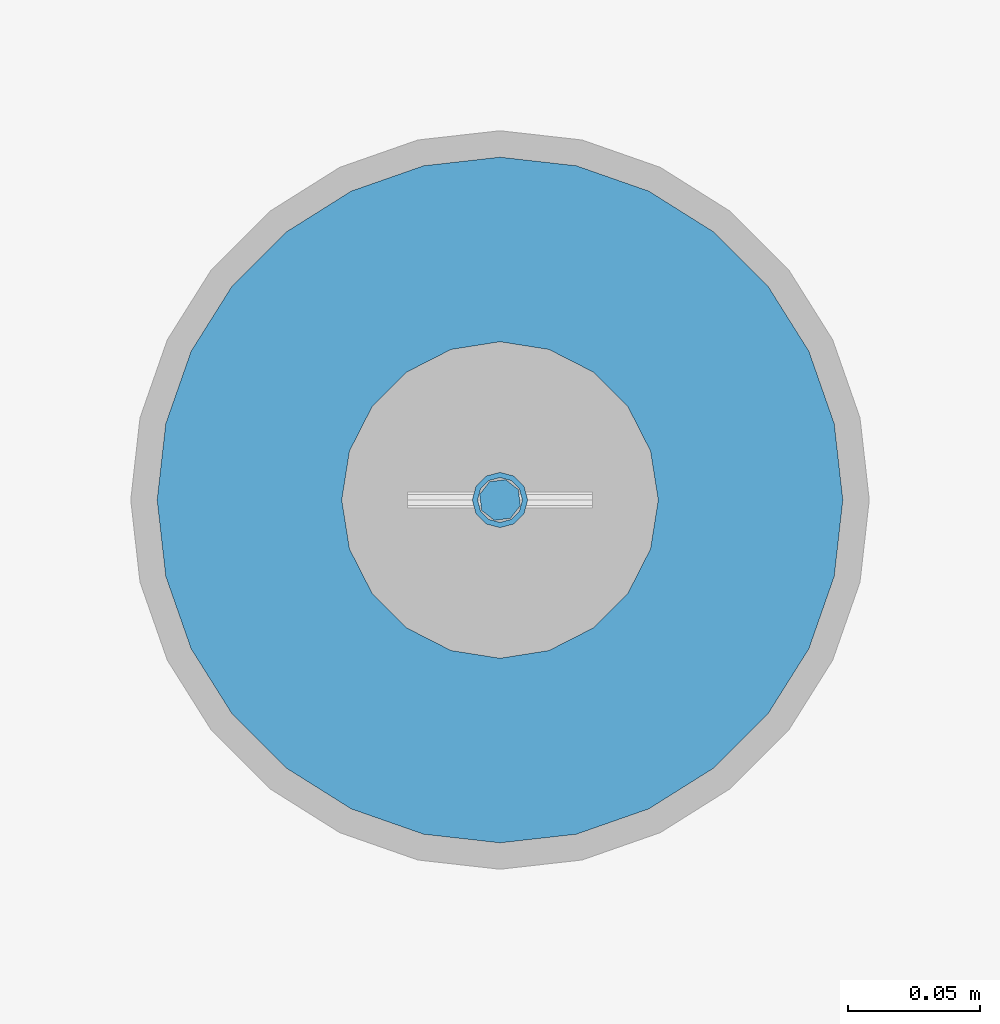
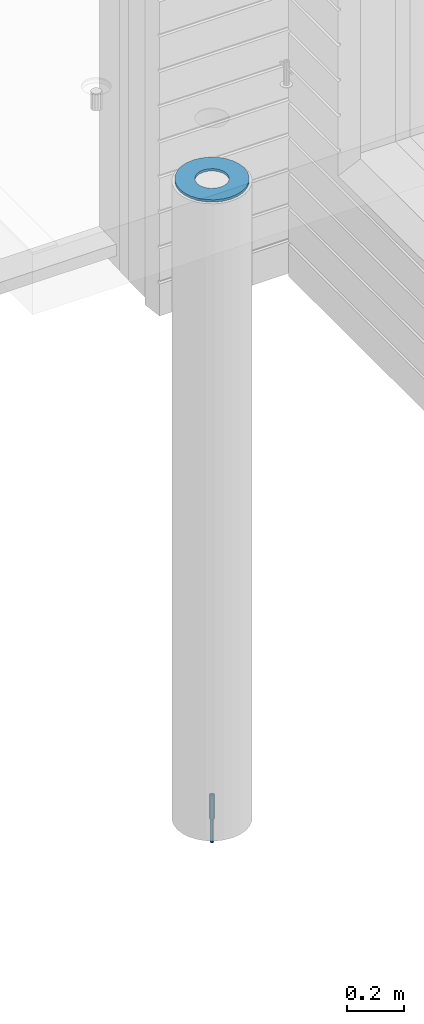
# One storey, part 7 of 309: 3 columns, 3 elements without a shape of their own.
"""IFC2X3 building model written with IfcOpenShell, lengths in millimetres."""

from ifc_helpers import new_model, si_unit, frame, origin_with_axes, place, context, subcontext, project, spatial, faceted_brep, material, type_object, element, aggregate, save


model = new_model("IFC2X3")

# Units and contexts
model_context = context("Model", 3, precision=1e-05, world=origin_with_axes())
body_context = subcontext(model_context, "Body", "Model", "MODEL_VIEW")
ifc_project = project(units=[si_unit("LENGTHUNIT", "METRE", prefix="MILLI"), si_unit("AREAUNIT", "SQUARE_METRE"), si_unit("VOLUMEUNIT", "CUBIC_METRE"), si_unit("MASSUNIT", "GRAM", prefix="KILO"), si_unit("TIMEUNIT", "SECOND"), si_unit("PLANEANGLEUNIT", "RADIAN"), si_unit("SOLIDANGLEUNIT", "STERADIAN"), si_unit("THERMODYNAMICTEMPERATUREUNIT", "DEGREE_CELSIUS"), si_unit("LUMINOUSINTENSITYUNIT", "LUMEN")], contexts=[model_context])

# Site, building, storey
site_placement = place(None, origin_with_axes())
site = spatial("IfcSite", under=ifc_project, at=site_placement, CompositionType="ELEMENT")
building_placement = place(site_placement, origin_with_axes())
building = spatial("IfcBuilding", under=site, at=building_placement, CompositionType="ELEMENT")
storey_placement = place(building_placement, origin_with_axes())
storey = spatial("IfcBuildingStorey", under=building, at=storey_placement, Name="7", CompositionType="ELEMENT", Elevation=0.0)

# Assemblies, columns
assembly_1_placement = place(storey_placement, origin_with_axes())
assembly_1 = element("IfcElementAssembly", 1, at=assembly_1_placement, inside=storey, AssemblyPlace="NOTDEFINED", PredefinedType="REINFORCEMENT_UNIT")
assembly_2_placement = place(assembly_1_placement, origin_with_axes())
assembly_2 = element("IfcElementAssembly", 2, at=assembly_2_placement, Name="Steel Assembly", AssemblyPlace="NOTDEFINED", PredefinedType="RIGID_FRAME")
ifc_material_1 = material(Name="STEEL/S235JR")
column_type_1 = type_object("IfcColumnType", Name="D16", PredefinedType="NOTDEFINED")
column_1_placement = place(assembly_2_placement, frame((7850.00048014349, 7949.98420120467, 99625.0), z_axis=(-0.261346946111888, -0.96524492941325, 0.0), x_axis=(0.0, 0.0, 1.0)))
column_1 = element("IfcColumn", 3, at=column_1_placement, type_object=column_type_1, material=ifc_material_1, Name="M16", ObjectType="D16", context=body_context, shape_type="Brep", body=[
    faceted_brep([(0.0, -8.0, 0.0), (0.0, -5.65685424949334, -5.65685424949334), (150.0, -5.65685424949697, -5.65685424949334), (150.0, -8.00000000000364, 0.0), (0.0, 0.0, -8.0), (150.0, -7.27595761418343e-12, -7.99999999999636), (0.0, 5.65685424949334, -5.65685424949334), (150.0, 5.6568542494897, -5.65685424949334), (0.0, 8.0, 0.0), (150.0, 8.0, -3.63797880709171e-12), (0.0, 5.65685424949334, 5.65685424949334), (150.0, 5.65685424949334, 5.65685424949697), (0.0, 0.0, 8.0), (150.0, -3.63797880709171e-12, 8.0), (0.0, -5.65685424949334, 5.65685424949334), (150.0, -5.65685424949334, 5.6568542494897)], [[[0, 1, 2, 3]], [[1, 4, 5, 2]], [[4, 6, 7, 5]], [[6, 8, 9, 7]], [[8, 10, 11, 9]], [[10, 12, 13, 11]], [[12, 14, 15, 13]], [[14, 0, 3, 15]], [[5, 7, 9, 11, 13, 15, 3, 2]], [[14, 12, 10, 8, 6, 4, 1, 0]]]),
])
aggregate(assembly_2, [column_1])
assembly_3_placement = place(assembly_1_placement, origin_with_axes())
assembly_3 = element("IfcElementAssembly", 4, at=assembly_3_placement, Name="Steel Assembly", AssemblyPlace="NOTDEFINED", PredefinedType="RIGID_FRAME")
ifc_material_2 = material(Name="STEEL/Steel_Undefined")
column_type_2 = type_object("IfcColumnType", PredefinedType="NOTDEFINED")
column_2_placement = place(assembly_3_placement, frame((7849.99879520436, 7949.98488883804, 99725.0), z_axis=(0.0, 1.0, 0.0), x_axis=(0.0, 0.0, 1.0)))
column_2 = element("IfcColumn", 5, at=column_2_placement, type_object=column_type_2, material=ifc_material_2, context=body_context, shape_type="Brep", body=[
    faceted_brep([(0.0, -8.49999999999272, -1.45519152283669e-11), (0.0, -7.36121593215648, 4.24999999998545), (100.000000000262, -7.36121593215648, 4.24999999998545), (100.000000000262, -8.49999999999272, -1.45519152283669e-11), (0.0, -4.24999999998545, 7.36121593216376), (100.000000000262, -4.24999999998545, 7.36121593216376), (0.0, 1.45519152283669e-11, 8.49999999998545), (100.000000000262, 1.45519152283669e-11, 8.49999999998545), (0.0, 4.25000000001455, 7.36121593216376), (100.000000000262, 4.25000000001455, 7.36121593216376), (0.0, 7.36121593217104, 4.24999999998545), (100.000000000262, 7.36121593217104, 4.24999999998545), (0.0, 8.50000000000728, 0.0), (100.000000000262, 8.50000000000728, 0.0), (0.0, 7.36121593217104, -4.25000000001455), (100.000000000262, 7.36121593217104, -4.25000000001455), (0.0, 4.25000000000728, -7.36121593219286), (100.000000000262, 4.25000000000728, -7.36121593219286), (0.0, 7.27595761418343e-12, -8.5), (100.000000000262, 7.27595761418343e-12, -8.5), (0.0, -4.24999999999272, -7.36121593217831), (100.000000000262, -4.24999999999272, -7.36121593217831), (0.0, -7.36121593215648, -4.25), (100.000000000262, -7.36121593215648, -4.25), (0.0, -10.4999999999927, -1.45519152283669e-11), (0.0, -9.09326673972828, -5.25000000001455), (100.000000000262, -9.09326673972828, -5.25000000001455), (100.000000000262, -10.4999999999927, -1.45519152283669e-11), (0.0, -5.24999999998545, -9.09326673974283), (100.000000000262, -5.24999999998545, -9.09326673974283), (0.0, 7.27595761418343e-12, -10.5), (100.000000000262, 7.27595761418343e-12, -10.5), (0.0, 5.25000000001455, -9.09326673975738), (100.000000000262, 5.25000000001455, -9.09326673975738), (0.0, 9.09326673975011, -5.25000000001455), (100.000000000262, 9.09326673975011, -5.25000000001455), (0.0, 10.5000000000073, -1.45519152283669e-11), (100.000000000262, 10.5000000000073, -1.45519152283669e-11), (0.0, 9.09326673975011, 5.25), (100.000000000262, 9.09326673975011, 5.25), (0.0, 5.25000000000728, 9.09326673972828), (100.000000000262, 5.25000000000728, 9.09326673972828), (0.0, 1.45519152283669e-11, 10.4999999999854), (100.000000000262, 1.45519152283669e-11, 10.4999999999854), (0.0, -5.24999999999272, 9.09326673972828), (100.000000000262, -5.24999999999272, 9.09326673972828), (0.0, -9.09326673972828, 5.24999999998545), (100.000000000262, -9.09326673972828, 5.24999999998545)], [[[0, 1, 2, 3]], [[1, 4, 5, 2]], [[4, 6, 7, 5]], [[6, 8, 9, 7]], [[8, 10, 11, 9]], [[10, 12, 13, 11]], [[12, 14, 15, 13]], [[14, 16, 17, 15]], [[16, 18, 19, 17]], [[18, 20, 21, 19]], [[20, 22, 23, 21]], [[22, 0, 3, 23]], [[24, 25, 26, 27]], [[25, 28, 29, 26]], [[28, 30, 31, 29]], [[30, 32, 33, 31]], [[32, 34, 35, 33]], [[34, 36, 37, 35]], [[36, 38, 39, 37]], [[38, 40, 41, 39]], [[40, 42, 43, 41]], [[42, 44, 45, 43]], [[44, 46, 47, 45]], [[46, 24, 27, 47]], [[29, 31, 33, 35, 37, 39, 41, 43, 45, 47, 27, 26], [5, 7, 9, 11, 13, 15, 17, 19, 21, 23, 3, 2]], [[46, 44, 42, 40, 38, 36, 34, 32, 30, 28, 25, 24], [22, 20, 18, 16, 14, 12, 10, 8, 6, 4, 1, 0]]]),
])
aggregate(assembly_3, [column_2])
ifc_material_3 = material()
column_type_3 = type_object("IfcColumnType", Name="D260", PredefinedType="NOTDEFINED")
column_3_placement = place(assembly_1_placement, frame((7849.99879520436, 7949.98488883804, 102435.0), z_axis=(-1.0, 3.00000001838171e-08, 0.0), x_axis=(0.0, 0.0, 1.0)))
column_3 = element("IfcColumn", 6, at=column_3_placement, type_object=column_type_3, material=ifc_material_3, Name="60", ObjectType="D260", context=body_context, shape_type="Brep", body=[
    faceted_brep([(10.0, -18.541019662498, -57.0633909777098), (0.0, -18.541019662498, -57.0633909777098), (0.0, -35.2671151375471, -48.5410196624944), (10.0, -35.2671151375471, -48.5410196624944), (0.0, -48.541019662498, -35.2671151375471), (10.0, -48.541019662498, -35.2671151375471), (0.0, -57.0633909777098, -18.5410196624944), (10.0, -57.0633909777098, -18.5410196624944), (0.0, -60.0, 0.0), (10.0, -60.0, 0.0), (0.0, -57.0633909777098, 18.5410196624944), (10.0, -57.0633909777098, 18.5410196624944), (0.0, -48.541019662498, 35.2671151375471), (10.0, -48.541019662498, 35.2671151375471), (0.0, -35.2671151375471, 48.5410196624944), (10.0, -35.2671151375471, 48.5410196624944), (0.0, -18.541019662498, 57.0633909777098), (10.0, -18.541019662498, 57.0633909777098), (0.0, 0.0, 60.0), (10.0, 0.0, 60.0), (0.0, 18.541019662498, 57.0633909777098), (10.0, 18.541019662498, 57.0633909777098), (0.0, 35.2671151375471, 48.5410196624944), (10.0, 35.2671151375471, 48.5410196624944), (0.0, 48.541019662498, 35.2671151375471), (10.0, 48.541019662498, 35.2671151375471), (0.0, 57.0633909777098, 18.5410196624944), (10.0, 57.0633909777098, 18.5410196624944), (0.0, 60.0, 0.0), (10.0, 60.0, 0.0), (0.0, 57.0633909777098, -18.5410196624944), (10.0, 57.0633909777098, -18.5410196624944), (0.0, 48.541019662498, -35.2671151375471), (10.0, 48.541019662498, -35.2671151375471), (0.0, 35.2671151375471, -48.5410196624944), (10.0, 35.2671151375471, -48.5410196624944), (0.0, 18.541019662498, -57.0633909777098), (10.0, 18.541019662498, -57.0633909777098), (0.0, 0.0, -60.0), (10.0, 0.0, -60.0), (0.0, -126.740628583637, -28.9277214143222), (0.0, -117.125952827315, -56.4048860852854), (10.0, -117.125952827315, -56.4048860852854), (10.0, -126.740628583637, -28.9277214143222), (0.0, -101.638092720845, -81.0536742416371), (10.0, -101.638092720845, -81.0536742416371), (0.0, -81.0536742416371, -101.638092720845), (10.0, -81.0536742416371, -101.638092720845), (0.0, -56.4048860852818, -117.125952827315), (10.0, -56.4048860852818, -117.125952827315), (0.0, -28.9277214143222, -126.740628583641), (10.0, -28.9277214143222, -126.740628583641), (0.0, 0.0, -130.0), (10.0, 0.0, -130.0), (0.0, 28.9277214143222, -126.740628583641), (10.0, 28.9277214143222, -126.740628583641), (0.0, 56.4048860852818, -117.125952827315), (10.0, 56.4048860852818, -117.125952827315), (0.0, 81.0536742416371, -101.638092720845), (10.0, 81.0536742416371, -101.638092720845), (0.0, 101.638092720845, -81.0536742416371), (10.0, 101.638092720845, -81.0536742416371), (0.0, 117.125952827315, -56.4048860852854), (10.0, 117.125952827315, -56.4048860852854), (0.0, 126.740628583637, -28.9277214143222), (10.0, 126.740628583637, -28.9277214143222), (0.0, 130.0, -1.81898940354586e-12), (10.0, 130.0, 0.0), (0.0, 126.740628583637, 28.9277214143222), (10.0, 126.740628583637, 28.9277214143222), (0.0, 117.125952827315, 56.4048860852854), (10.0, 117.125952827315, 56.4048860852854), (0.0, 101.638092720845, 81.0536742416371), (10.0, 101.638092720845, 81.0536742416371), (0.0, 81.0536742416371, 101.638092720845), (10.0, 81.0536742416371, 101.638092720845), (0.0, 56.4048860852818, 117.125952827315), (10.0, 56.4048860852818, 117.125952827315), (0.0, 28.9277214143222, 126.740628583641), (10.0, 28.9277214143222, 126.740628583641), (0.0, 0.0, 130.0), (10.0, 0.0, 130.0), (0.0, -28.9277214143222, 126.740628583641), (10.0, -28.9277214143222, 126.740628583641), (0.0, -56.4048860852818, 117.125952827315), (10.0, -56.4048860852818, 117.125952827315), (0.0, -81.0536742416371, 101.638092720845), (10.0, -81.0536742416371, 101.638092720845), (0.0, -101.638092720845, 81.0536742416371), (10.0, -101.638092720845, 81.0536742416371), (0.0, -117.125952827315, 56.4048860852854), (10.0, -117.125952827315, 56.4048860852854), (0.0, -126.740628583637, 28.9277214143222), (10.0, -126.740628583637, 28.9277214143222), (0.0, -130.0, -3.63797880709171e-12), (10.0, -130.0, 0.0)], [[[0, 1, 2, 3]], [[3, 2, 4, 5]], [[5, 4, 6, 7]], [[7, 6, 8, 9]], [[9, 8, 10, 11]], [[11, 10, 12, 13]], [[13, 12, 14, 15]], [[15, 14, 16, 17]], [[17, 16, 18, 19]], [[19, 18, 20, 21]], [[21, 20, 22, 23]], [[23, 22, 24, 25]], [[25, 24, 26, 27]], [[27, 26, 28, 29]], [[29, 28, 30, 31]], [[31, 30, 32, 33]], [[33, 32, 34, 35]], [[35, 34, 36, 37]], [[37, 36, 38, 39]], [[39, 38, 1, 0]], [[40, 41, 42, 43]], [[41, 44, 45, 42]], [[44, 46, 47, 45]], [[46, 48, 49, 47]], [[48, 50, 51, 49]], [[50, 52, 53, 51]], [[52, 54, 55, 53]], [[54, 56, 57, 55]], [[56, 58, 59, 57]], [[58, 60, 61, 59]], [[60, 62, 63, 61]], [[62, 64, 65, 63]], [[64, 66, 67, 65]], [[66, 68, 69, 67]], [[68, 70, 71, 69]], [[70, 72, 73, 71]], [[72, 74, 75, 73]], [[74, 76, 77, 75]], [[76, 78, 79, 77]], [[78, 80, 81, 79]], [[80, 82, 83, 81]], [[82, 84, 85, 83]], [[84, 86, 87, 85]], [[86, 88, 89, 87]], [[88, 90, 91, 89]], [[90, 92, 93, 91]], [[92, 94, 95, 93]], [[42, 45, 47, 49, 51, 53, 55, 57, 59, 61, 63, 65, 67, 69, 71, 73, 75, 77, 79, 81, 83, 85, 87, 89, 91, 93, 95, 43], [3, 5, 7, 9, 11, 13, 15, 17, 19, 21, 23, 25, 27, 29, 31, 33, 35, 37, 39, 0]], [[94, 40, 43, 95]], [[92, 90, 88, 86, 84, 82, 80, 78, 76, 74, 72, 70, 68, 66, 64, 62, 60, 58, 56, 54, 52, 50, 48, 46, 44, 41, 40, 94], [34, 32, 30, 28, 26, 24, 22, 20, 18, 16, 14, 12, 10, 8, 6, 4, 2, 1, 38, 36]]]),
])
aggregate(assembly_1, [assembly_3, assembly_2, column_3])

save(model, "model.ifc")
